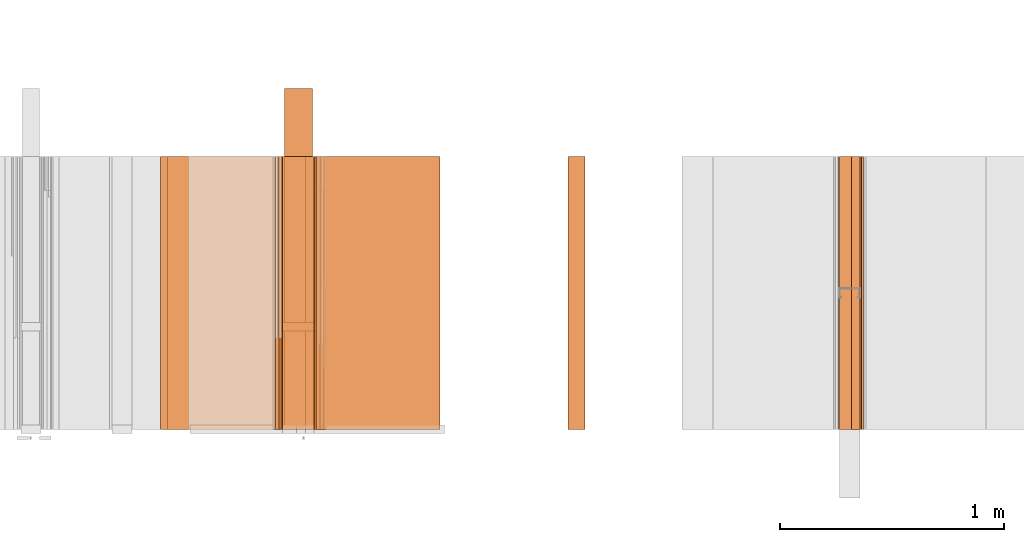
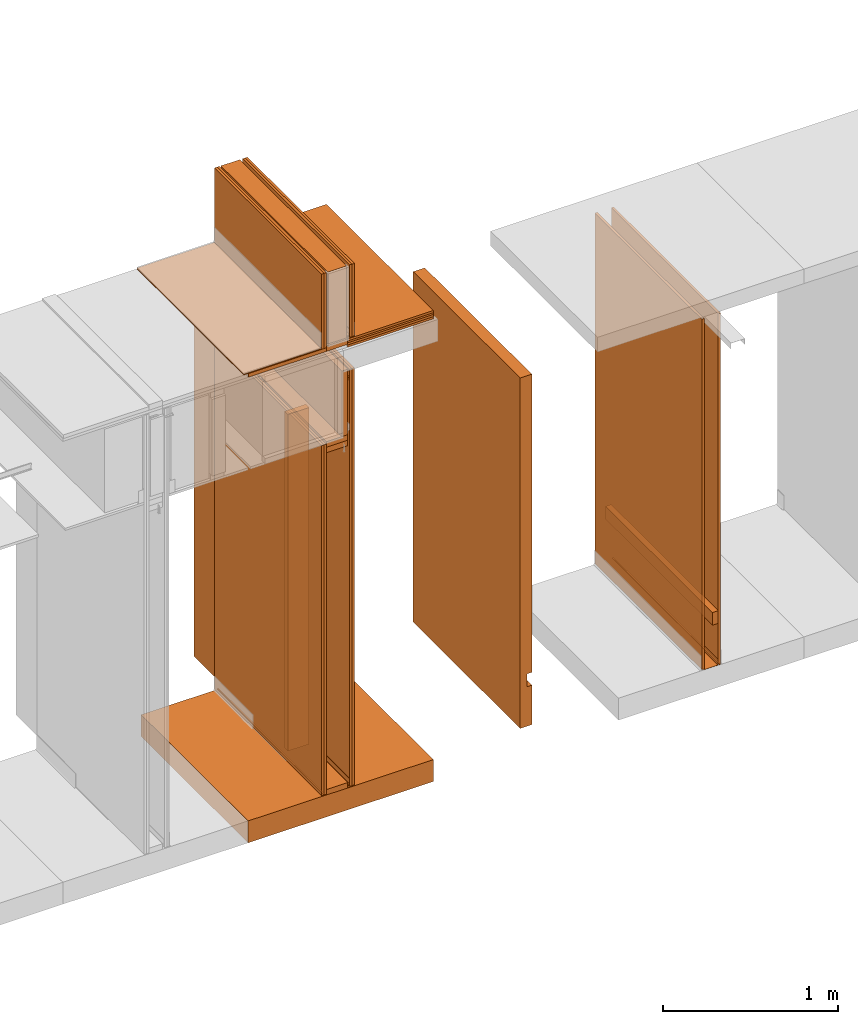
# One storey, part 11 of 38: 34 proxies.
"""IFC4 building model written with IfcOpenShell, lengths in feet."""

from ifc_helpers import new_model, entity, si_unit, converted_unit, frame, origin_with_axes, origin_2d_with_axis, place, context, subcontext, project, spatial, polyline, outline, extrude, material, element, save


model = new_model("IFC4")

# Units and contexts
model_context_1 = context("Model", 3, precision=1e-05, world=origin_with_axes())
plan_context = context("Plan", 2, precision=1e-05, world=origin_2d_with_axis())
model_context_2 = context("Model", 3, precision=1e-05, world=origin_with_axes())
context_of_model_1 = context(None, 3, precision=1e-05, world=origin_with_axes())
context_of_model_2 = context(None, 3, precision=1e-05, world=origin_with_axes())
body_context = subcontext(model_context_2, "Body", "Model", "MODEL_VIEW")
ifc_project = project(units=[converted_unit("PLANEANGLEUNIT", "degree", entity("IfcReal", 0.0174532925199433), si_unit("PLANEANGLEUNIT", "RADIAN"), dimensions=[0, 0, 0, 0, 0, 0, 0]), converted_unit("AREAUNIT", "square foot", entity("IfcReal", 0.09290304), si_unit("AREAUNIT", "SQUARE_METRE"), dimensions=[2, 0, 0, 0, 0, 0, 0]), converted_unit("LENGTHUNIT", "foot", entity("IfcReal", 0.3048), si_unit("LENGTHUNIT", "METRE"), dimensions=[1, 0, 0, 0, 0, 0, 0]), converted_unit("VOLUMEUNIT", "cubic foot", entity("IfcReal", 0.0283168467116885), si_unit("VOLUMEUNIT", "CUBIC_METRE"), dimensions=[3, 0, 0, 0, 0, 0, 0])], contexts=[model_context_1, plan_context, context_of_model_1, context_of_model_2])

# Site, building, storey
site_placement = place(None, origin_with_axes())
site = spatial("IfcSite", under=ifc_project, at=site_placement)
building_placement = place(site_placement, origin_with_axes())
building = spatial("IfcBuilding", under=site, at=building_placement, Name="Building")
storey_placement = place(building_placement, origin_with_axes())
storey = spatial("IfcBuildingStorey", under=building, at=storey_placement, Name="Storey")

# Proxies
ifc_material_1 = material(Category="sand")
proxy_1_placement = place(storey_placement, frame((1395.33335768332, 5.99999987860051, 0.0208333330815585), z_axis=(1.62920684942944e-07, -0.999999999999987, -1.23001694617954e-14), x_axis=(7.54979012640431e-08, 0.0, 0.999999999999997)))
element("IfcBuildingElementProxy", 1, at=proxy_1_placement, inside=storey, material=ifc_material_1, Name="Generic Models 138:Generic Models 1", PredefinedType="COMPLEX", context=body_context, shape_type="SweptSolid", body=[
    extrude(outline(polyline([(-0.0260419699942737, -4.00000004943587), (0.0260413650012626, -4.00000004943587), (0.0260419699942737, 4.00000004943587), (-0.0260413650012626, 4.00000004943587), (-0.0260419699942737, -4.00000004943587)])), frame((4.00000004943587, -0.0260413650012626, -3.91106639637913e-07), z_axis=(-1.16558848618949e-14, 0.0, -1.0), x_axis=(0.0, 1.0, 0.0)), (0.0, -1.16558848618949e-14, -1.0), 4.00000000752362),
])
proxy_2_placement = place(storey_placement, frame((1387.33330674059, 5.99999987860051, 10.1588545196013), z_axis=(4.37113882867379e-08, -0.999999999999999, -8.51092183247426e-15), x_axis=(1.94707183709394e-07, 0.0, 0.999999999999981)))
element("IfcBuildingElementProxy", 2, at=proxy_2_placement, inside=storey, Name="Generic Models 491:Generic Models 1", PredefinedType="COMPLEX", context=body_context, shape_type="SweptSolid", body=[
    extrude(outline(polyline([(-0.0208335148850138, -0.92447918700421), (0.0208331543336234, -0.92447918700421), (0.0208335148850138, 0.92447918700421), (-0.0208331543336234, 0.92447918700421), (-0.0208335148850138, -0.92447918700421)])), frame((0.0208335148850138, -0.92447918700421, -5.0131307678986e-07), z_axis=(0.0, 1.19209289550781e-07, -1.0), x_axis=(-1.0, 0.0, 0.0)), (0.0, -3.01153102455487e-09, -1.0), 4.00000000752362),
])
proxy_3_placement = place(storey_placement, frame((1387.33330674059, 5.99999987860051, 10.1093748423058), z_axis=(4.37113882867379e-08, -0.999999999999999, -8.51092183247426e-15), x_axis=(1.94707183709394e-07, 0.0, 0.999999999999981)))
element("IfcBuildingElementProxy", 3, at=proxy_3_placement, inside=storey, Name="Generic Models 492:Generic Models 1", PredefinedType="COMPLEX", context=body_context, shape_type="SweptSolid", body=[
    extrude(outline(polyline([(-0.0247397637874709, -0.92447918700421), (0.0247394032360805, -0.92447918700421), (0.0247397637874709, 0.92447918700421), (-0.0247394032360805, 0.92447918700421), (-0.0247397637874709, -0.92447918700421)])), frame((0.0247397637874709, -0.92447918700421, -5.0131307678986e-07), z_axis=(0.0, 1.19209289550781e-07, -1.0), x_axis=(-1.0, 0.0, 0.0)), (0.0, -3.01153102455487e-09, -1.0), 4.00000000752362),
])
proxy_4_placement = place(storey_placement, frame((1387.2083528774, 5.99999987860051, 8.06249971464863), z_axis=(4.37113882867379e-08, -0.999999999999999, -8.51092183247426e-15), x_axis=(1.94707183709394e-07, 0.0, 0.999999999999981)))
element("IfcBuildingElementProxy", 4, at=proxy_4_placement, inside=storey, Name="Generic Models 493:Generic Models 1", PredefinedType="COMPLEX", context=body_context, shape_type="SweptSolid", body=[
    extrude(outline(polyline([(-0.748697844311947, -0.0625000007724355), (0.748697893200271, -0.0625000007724355), (0.748697893200271, 0.0625000007724355), (-0.748697893200271, 0.0625000007724355), (-0.748697844311947, -0.0625000007724355)])), frame((0.748697893200271, -0.0624998541074631, -3.98557174431872e-07), z_axis=(-2.35432113122316e-14, 1.19209303761636e-07, -1.0), x_axis=(-1.0, -1.95893392174185e-07, 0.0)), (3.06085023993319e-09, 4.40009660651608e-11, -1.0), 4.00000000752362),
])
ifc_material_2 = material(Category="InsulationBatt")
proxy_5_placement = place(storey_placement, frame((1386.90327721944, 5.99999987860051, 10.2830629336239), z_axis=(4.37113882867379e-08, -0.999999999999999, -8.51092183247426e-15), x_axis=(1.94707183709394e-07, 0.0, 0.999999999999981)))
element("IfcBuildingElementProxy", 5, at=proxy_5_placement, inside=storey, material=ifc_material_2, Name="Generic Models 496:Generic Models 1", PredefinedType="COMPLEX", context=body_context, shape_type="SweptSolid", body=[
    extrude(outline(polyline([(-0.820806020201035, -0.20460231752768), (0.820806020201035, -0.20460231752768), (0.820805922424386, 0.20460231752768), (-0.820806020201035, 0.20460231752768), (-0.820806020201035, -0.20460231752768)])), frame((0.820806020201035, -0.204602158640626, -4.15497091384278e-07), z_axis=(-2.31266422028378e-14, 1.19209289550781e-07, -1.0), x_axis=(1.0, 1.94707183709397e-07, 0.0)), (-9.9594013036608e-09, 3.24397553264077e-09, -1.0), 4.00000000752362),
])
proxy_6_placement = place(storey_placement, frame((1391.05729230746, 5.99999909638733, 0.0546877993529863), z_axis=(1.62920684942944e-07, -0.999999999999987, -1.23001694617954e-14), x_axis=(7.54979012640431e-08, 0.0, 0.999999999999997)))
element("IfcBuildingElementProxy", 6, at=proxy_6_placement, inside=storey, material=ifc_material_2, Name="Generic Models 157:Generic Models 1", PredefinedType="COMPLEX", context=body_context, shape_type="SweptSolid", body=[
    extrude(outline(polyline([(1.62270213440647, -0.0872395766454106), (2.52313129701639, -0.0872395766454106), (2.52313129701639, 0.162760426444331), (-5.47686899740865, 0.162760365333926), (-5.47686860630206, -0.0872396194226942), (1.33103546820913, -0.0872395766454106), (1.33103546820913, 0.0117187520545318), (1.62270213440647, 0.0117187635127328), (1.62270213440647, -0.0872395766454106)])), frame((2.52313129701639, -0.162760218668954, -3.91106593014374e-07), z_axis=(-6.06266415447755e-15, -2.11475937672914e-14, -1.0), x_axis=(-1.0, -8.14417049355143e-08, 0.0)), (3.31386740271e-09, 5.71793279391386e-10, -1.0), 4.00000000752362),
])
ifc_material_3 = material()
proxy_7_placement = place(storey_placement, frame((1395.03128572399, 6.00000026970711, 2.46003406487815e-14), z_axis=(1.62920684942944e-07, -0.999999999999987, -1.23001694617954e-14), x_axis=(7.54979012640431e-08, 0.0, 0.999999999999997)))
element("IfcBuildingElementProxy", 7, at=proxy_7_placement, inside=storey, material=ifc_material_3, Name="Generic Models 15:Generic Models 1", PredefinedType="COMPLEX", context=body_context, shape_type="SweptSolid", body=[
    extrude(outline(polyline([(-0.0664062573136933, -0.151041662931599), (0.0690104038970364, -0.151041662931599), (0.0690104283411985, 0.151041662931599), (-0.0664062328695312, 0.151041662931599), (-0.0664062328695312, 0.145833333098669), (0.0638020923972286, 0.145833333098669), (0.0638020679530666, -0.14583334532075), (-0.0664062573136933, -0.14583334532075), (-0.0664062573136933, -0.151041662931599)])), frame((0.0690104283411985, -0.151041662931599, -8.48839891821795e-16), z_axis=(-1.2300178779158e-14, 3.03913346414728e-21, -1.0), x_axis=(-1.0, 0.0, 1.23001677677296e-14)), (1.22990073325919e-14, 0.0, -1.0), 4.00000000752362),
])
proxy_8_placement = place(storey_placement, frame((1394.97912149104, 5.99999987860051, 0.0208333330815585), z_axis=(1.62920684942944e-07, -0.999999999999987, -1.23001694617954e-14), x_axis=(7.54979012640431e-08, 0.0, 0.999999999999997)))
element("IfcBuildingElementProxy", 8, at=proxy_8_placement, inside=storey, material=ifc_material_1, Name="Generic Models 16:Generic Models 1", PredefinedType="COMPLEX", context=body_context, shape_type="SweptSolid", body=[
    extrude(outline(polyline([(-0.0260419699942737, -4.00000004943587), (0.0260413650012626, -4.00000004943587), (0.0260419699942737, 4.00000004943587), (-0.0260413650012626, 4.00000004943587), (-0.0260419699942737, -4.00000004943587)])), frame((4.00000004943587, -0.0260413650012626, -3.91106639637913e-07), z_axis=(-1.16558848618949e-14, 0.0, -1.0), x_axis=(0.0, 1.0, 0.0)), (0.0, -1.16558848618949e-14, -1.0), 4.00000000752362),
])
ifc_material_4 = material(Name="ACOUSTICAL SEALANT OR FIRE SEALANT, IF RATED WALL", Category="sealant")
proxy_9_placement = place(storey_placement, frame((1395.34967777923, 5.99999987860051, 0.0), z_axis=(1.62920684942944e-07, -0.999999999999987, -1.23001694617954e-14), x_axis=(7.54979012640431e-08, 0.0, 0.999999999999997)))
element("IfcBuildingElementProxy", 9, at=proxy_9_placement, inside=storey, material=ifc_material_4, Name="Generic Models 17:Generic Models 1", PredefinedType="COMPLEX", context=body_context, shape_type="SweptSolid", body=[
    extrude(outline(polyline([(0.0200664020800997, 8.59128858751497e-10), (-0.0066432067293312, 0.0162221848221589), (-0.0159632080916579, 0.00969531855440828), (-0.0174579961015171, -0.00158422060519838), (0.00925161041627367, -0.0178064048544472), (0.0107464022455331, -0.00652686626775058), (0.0200664020800997, 8.59128858751497e-10)])), frame((0.0104166680685394, -0.0185779756634176, -1.2812678144933e-16), z_axis=(-1.23001677677296e-14, 6.41066287393143e-22, -1.0), x_axis=(-0.519109845161438, -0.854707539081573, 6.38513764431026e-15)), (1.60595958753618e-09, 3.2119169546263e-09, -1.0), 4.0),
])
ifc_material_5 = material(Category="wood1")
proxy_10_placement = place(storey_placement, frame((1395.20830369684, 5.99999987860051, 0.955116717521287), z_axis=(1.62920684942944e-07, -0.999999999999987, -1.23001694617954e-14), x_axis=(7.54979012640431e-08, 0.0, 0.999999999999997)))
element("IfcBuildingElementProxy", 10, at=proxy_10_placement, inside=storey, material=ifc_material_5, Name="Generic Models 197:Generic Models 1", PredefinedType="COMPLEX", context=body_context, shape_type="SweptSolid", body=[
    extrude(outline(polyline([(-0.0625000129945165, -0.145833333098669), (0.0624999885503545, -0.145833333098669), (0.0625000129945165, 0.145833320876588), (-0.0624999885503545, 0.145833333098669), (-0.0625000129945165, -0.145833333098669)])), frame((0.145833333098669, -0.0624999885503545, -3.91106593014374e-07), z_axis=(0.0, 0.0, -1.0), x_axis=(0.0, -1.0, 0.0)), (0.0, 0.0, -1.0), 4.00000000752362),
])
proxy_11_placement = place(storey_placement, frame((1395.20830369684, 5.99999987860051, 0.955116717521287), z_axis=(1.62920684942944e-07, -0.999999999999987, -1.23001694617954e-14), x_axis=(7.54979012640431e-08, 0.0, 0.999999999999997)))
element("IfcBuildingElementProxy", 11, at=proxy_11_placement, inside=storey, material=ifc_material_5, Name="Generic Models 197:Generic Models 1", PredefinedType="COMPLEX", context=body_context, shape_type="SweptSolid", body=[
    extrude(outline(polyline([(-0.0625000007724355, -0.145833333098669), (0.0625000007724355, -0.145833333098669), (0.062499994661395, 0.145833333098669), (-0.062500006883476, 0.145833320876588), (-0.0625000007724355, -0.145833333098669)])), frame((0.145833333098669, -0.0624999885503545, -3.91106593014374e-07), z_axis=(0.0, 0.0, -1.0), x_axis=(-9.77766489995702e-08, 1.0, 0.0)), (-5.09253250680075e-10, -1.52775991857368e-09, -1.0), 4.00000000752362),
])
ifc_material_6 = material(Name="STRUCTURAL FLOOR", Category="concrete")
proxy_12_placement = place(storey_placement, frame((1385.18225802524, 5.99999987860051, -0.500000006179484), z_axis=(4.37113882867379e-08, -0.999999999999999, -8.51092183247426e-15), x_axis=(1.94707183709394e-07, 0.0, 0.999999999999981)))
element("IfcBuildingElementProxy", 12, at=proxy_12_placement, inside=storey, material=ifc_material_6, Name="Generic Models 238:Generic Models 1", PredefinedType="COMPLEX", context=body_context, shape_type="SweptSolid", body=[
    extrude(outline(polyline([(-0.250000003089742, -2.00000002471794), (0.250000003089742, -2.00000002471794), (0.250000003089742, 2.00000002471794), (-0.250000003089742, 2.00000002471794), (-0.250000003089742, -2.00000002471794)])), frame((0.250000394196335, -2.00000002471794, -6.29525198374314e-07), z_axis=(0.0, 1.19209289550781e-07, -1.0), x_axis=(1.0, 1.94707183709397e-07, 0.0)), (4.23038687413779e-10, -9.26340160134487e-09, -1.0), 4.00000000752362),
])
proxy_13_placement = place(storey_placement, frame((1386.87504245227, 5.99999987860051, 0.0), z_axis=(4.37113882867379e-08, -0.999999999999999, -8.51092183247426e-15), x_axis=(1.94707183709394e-07, 0.0, 0.999999999999981)))
element("IfcBuildingElementProxy", 13, at=proxy_13_placement, inside=storey, Name="Generic Models 435:Generic Models 1", PredefinedType="COMPLEX", context=body_context, shape_type="SweptSolid", body=[
    extrude(outline(polyline([(-0.229166659313863, -0.0625000007724355), (0.229166659313863, -0.0625000007724355), (0.229166659313863, 0.0625000007724355), (-0.229166683758025, 0.062499994661395), (-0.229166659313863, -0.0625000007724355)])), frame((0.0625000435497191, -0.229166659313863, -4.18425376004021e-07), z_axis=(0.0, 1.1920923981279e-07, -1.0), x_axis=(-1.94707183709397e-07, 1.0, 1.1920923981279e-07)), (-6.05387917573807e-09, -4.60778332156409e-10, -1.0), 4.00000000752362),
])
proxy_14_placement = place(storey_placement, frame((1387.37495802832, 5.99999987860051, 0.0208333330815585), z_axis=(4.37113882867379e-08, -0.999999999999999, -8.51092183247426e-15), x_axis=(1.94707183709394e-07, 0.0, 0.999999999999981)))
element("IfcBuildingElementProxy", 14, at=proxy_14_placement, inside=storey, Name="Generic Models 444:Generic Models 1", PredefinedType="COMPLEX", context=body_context, shape_type="SweptSolid", body=[
    extrude(outline(polyline([(-4.75911487118779, -0.0260416674977682), (4.75911487118779, -0.0260416674977682), (4.75911487118779, 0.0260416705532884), (-4.75911487118779, 0.0260416674977682), (-4.75911487118779, -0.0260416674977682)])), frame((4.75911487118779, -0.02604074167513, -3.94211021364806e-07), z_axis=(-3.29951011987777e-14, 1.19209154547661e-07, -1.0), x_axis=(1.0, 1.94707197920252e-07, -9.79668311805546e-15)), (-1.26761301455502e-09, 1.58962953911157e-10, -1.0), 4.00000000752362),
])
ifc_material_7 = material(Name="ACOUSTICAL SEALANT", Category="sealant")
proxy_15_placement = place(storey_placement, frame((1386.82287821932, 5.99999987860051, 0.0), z_axis=(4.37113882867379e-08, -0.999999999999999, -8.51092183247426e-15), x_axis=(1.94707183709394e-07, 0.0, 0.999999999999981)))
element("IfcBuildingElementProxy", 15, at=proxy_15_placement, inside=storey, material=ifc_material_7, Name="Generic Models 450:Generic Models 1", PredefinedType="COMPLEX", context=body_context, shape_type="SweptSolid", body=[
    extrude(outline(polyline([(0.0175297320783725, 1.21719171997307e-09), (-0.00760452534631872, 0.0185696447874344), (-0.0101125697065096, 0.00747135049587707), (-0.0199842895564484, 0.00181347361657025), (0.0051499686321229, -0.0167561721257142), (0.0150216861904215, -0.0110982927637972), (0.0175297320783725, 1.21719171997307e-09)])), frame((0.0104166711240596, -0.0171509025657545, -3.9315117507417e-07), z_axis=(1.14723269946382e-12, 1.19208550586336e-07, -1.0), x_axis=(-0.594228446483612, -0.804296314716339, -9.58762740310704e-08)), (-1.04803887790439e-10, 1.77274347978873e-10, -1.0), 4.00000000752362),
])
proxy_16_placement = place(storey_placement, frame((1386.77081410966, 5.99999987860051, 10.2083334146835), z_axis=(4.37113882867379e-08, -0.999999999999999, -8.51092183247426e-15), x_axis=(1.94707183709394e-07, 0.0, 0.999999999999981)))
element("IfcBuildingElementProxy", 16, at=proxy_16_placement, inside=storey, material=ifc_material_1, Name="Generic Models 452:Generic Models 1", PredefinedType="COMPLEX", context=body_context, shape_type="SweptSolid", body=[
    extrude(outline(polyline([(-0.0260416674977682, -0.858170779671256), (0.0260416674977682, -0.858170779671256), (0.0260416674977682, 0.858170779671256), (-0.0260416644422479, 0.858170779671256), (-0.0260416674977682, -0.858170779671256)])), frame((0.858170779671256, -0.026041499444154, -3.94210974741267e-07), z_axis=(-2.33946146282289e-14, 1.19209154547661e-07, -1.0), x_axis=(-1.94707169498542e-07, 1.0, 1.19209147442234e-07)), (2.84252066329316e-10, -1.26763999297452e-09, -1.0), 4.00000000752362),
])
proxy_17_placement = place(storey_placement, frame((1386.87504245227, 5.99999987860051, 7.81249968711472), z_axis=(4.37113882867379e-08, -0.999999999999999, -8.51092183247426e-15), x_axis=(1.94707183709394e-07, 0.0, 0.999999999999981)))
element("IfcBuildingElementProxy", 17, at=proxy_17_placement, inside=storey, Name="Generic Models 455:Generic Models 1", PredefinedType="COMPLEX", context=body_context, shape_type="SweptSolid", body=[
    extrude(outline(polyline([(-0.229166659313863, -0.0625000007724355), (0.229166659313863, -0.0625000007724355), (0.229166659313863, 0.0625000007724355), (-0.229166683758025, 0.062499994661395), (-0.229166659313863, -0.0625000007724355)])), frame((0.0625000435497191, -0.229166659313863, -4.18425376004021e-07), z_axis=(0.0, 1.1920923981279e-07, -1.0), x_axis=(-1.94707183709397e-07, 1.0, 1.1920923981279e-07)), (-6.05387917573807e-09, -4.60778332156409e-10, -1.0), 4.00000000752362),
])
proxy_18_placement = place(storey_placement, frame((1386.90327721944, 6.99999998873613, 0.125000001544871), z_axis=(4.37113882867379e-08, -0.999999999999999, -8.51092183247426e-15), x_axis=(1.94707183709394e-07, 0.0, 0.999999999999981)))
element("IfcBuildingElementProxy", 18, at=proxy_18_placement, inside=storey, Name="Generic Models 456:Generic Models 1", PredefinedType="COMPLEX", context=body_context, shape_type="SweptSolid", body=[
    extrude(outline(polyline([(-0.20460231752768, -3.83239327453253), (0.20460231752768, -3.83239327453253), (0.20460231752768, 3.83239327453253), (-0.20460231752768, 3.83239327453253), (-0.20460231752768, -3.83239327453253)])), frame((3.83239327453253, -0.204601571980737, -4.15497138007817e-07), z_axis=(-2.9337992403294e-14, 1.19209289550781e-07, -1.0), x_axis=(-1.94707183709397e-07, 1.0, 1.19209289550781e-07)), (-1.17899273677224e-10, -9.95937821102189e-09, -1.0), 4.00000000752362),
])
proxy_19_placement = place(storey_placement, frame((1386.87504245227, 5.99999987860051, 7.93749970088168), z_axis=(4.37113882867379e-08, -0.999999999999999, -8.51092183247426e-15), x_axis=(1.94707183709394e-07, 0.0, 0.999999999999981)))
element("IfcBuildingElementProxy", 19, at=proxy_19_placement, inside=storey, Name="Generic Models 457:Generic Models 1", PredefinedType="COMPLEX", context=body_context, shape_type="SweptSolid", body=[
    extrude(outline(polyline([(-0.229166659313863, -0.0625000007724355), (0.229166659313863, -0.0625000007724355), (0.229166659313863, 0.0625000007724355), (-0.229166683758025, 0.062499994661395), (-0.229166659313863, -0.0625000007724355)])), frame((0.0625000435497191, -0.229166659313863, -4.18425376004021e-07), z_axis=(0.0, 1.1920923981279e-07, -1.0), x_axis=(-1.94707183709397e-07, 1.0, 1.1920923981279e-07)), (-6.05387917573807e-09, -4.60778332156409e-10, -1.0), 4.00000000752362),
])
proxy_20_placement = place(storey_placement, frame((1386.82287821932, 5.99999987860051, 10.2083334146835), z_axis=(4.37113882867379e-08, -0.999999999999999, -8.51092183247426e-15), x_axis=(1.94707183709394e-07, 0.0, 0.999999999999981)))
element("IfcBuildingElementProxy", 20, at=proxy_20_placement, inside=storey, Name="Generic Models 458:Generic Models 1", PredefinedType="COMPLEX", context=body_context, shape_type="SweptSolid", body=[
    extrude(outline(polyline([(-0.858170779671256, -0.0260416674977682), (0.858170779671256, -0.0260416674977682), (0.858170779671256, 0.0260416644422479), (-0.858170779671256, 0.0260416674977682), (-0.858170779671256, -0.0260416674977682)])), frame((0.858170779671256, -0.026041499444154, -3.94210974741267e-07), z_axis=(-2.33946146282289e-14, 1.19209154547661e-07, -1.0), x_axis=(1.0, 1.94707183709397e-07, 0.0)), (-1.26763999297452e-09, -2.84249151993876e-10, -1.0), 4.00000000752362),
])
proxy_21_placement = place(storey_placement, frame((1386.82287821932, 5.99999987860051, 0.0208333330815585), z_axis=(4.37113882867379e-08, -0.999999999999999, -8.51092183247426e-15), x_axis=(1.94707183709394e-07, 0.0, 0.999999999999981)))
element("IfcBuildingElementProxy", 21, at=proxy_21_placement, inside=storey, Name="Generic Models 459:Generic Models 1", PredefinedType="COMPLEX", context=body_context, shape_type="SweptSolid", body=[
    extrude(outline(polyline([(-3.9947916829367, -0.0260416674977682), (3.9947916829367, -0.0260416674977682), (3.9947916829367, 0.0260416674977682), (-3.9947916829367, 0.0260416644422479), (-3.9947916829367, -0.0260416674977682)])), frame((3.9947916829367, -0.0260408883401024, -3.94211021364806e-07), z_axis=(-2.90771875707026e-14, 1.19209140336807e-07, -1.0), x_axis=(-1.0, -1.95043384110249e-07, 5.83554074000078e-15)), (1.26980481685024e-09, 4.38377840972226e-11, -1.0), 4.00000000752362),
])
proxy_22_placement = place(storey_placement, frame((1386.77081410966, 5.99999987860051, 0.0208333330815585), z_axis=(4.37113882867379e-08, -0.999999999999999, -8.51092183247426e-15), x_axis=(1.94707183709394e-07, 0.0, 0.999999999999981)))
element("IfcBuildingElementProxy", 22, at=proxy_22_placement, inside=storey, material=ifc_material_1, Name="Generic Models 460:Generic Models 1", PredefinedType="COMPLEX", context=body_context, shape_type="SweptSolid", body=[
    extrude(outline(polyline([(-3.9947916829367, -0.0260416674977682), (3.9947916829367, -0.0260416674977682), (3.9947916829367, 0.0260416644422479), (-3.9947916829367, 0.0260416674977682), (-3.9947916829367, -0.0260416674977682)])), frame((3.9947916829367, -0.0260408883401024, -3.94211021364806e-07), z_axis=(-2.90771875707026e-14, 1.19209140336807e-07, -1.0), x_axis=(1.0, 1.94707183709397e-07, -5.83554074000078e-15)), (-1.26761612317949e-09, -3.79597214772431e-10, -1.0), 4.00000000752362),
])
proxy_23_placement = place(storey_placement, frame((1387.42712226127, 5.99999987860051, 0.0208333330815585), z_axis=(4.37113882867379e-08, -0.999999999999999, -8.51092183247426e-15), x_axis=(1.94707183709394e-07, 0.0, 0.999999999999981)))
element("IfcBuildingElementProxy", 23, at=proxy_23_placement, inside=storey, Name="Generic Models 461:Generic Models 1", PredefinedType="COMPLEX", context=body_context, shape_type="SweptSolid", body=[
    extrude(outline(polyline([(-4.75911487118779, -0.0260416705532884), (4.75911487118779, -0.0260416705532884), (4.75911487118779, 0.0260416644422479), (-4.75911487118779, 0.0260416674977682), (-4.75911487118779, -0.0260416705532884)])), frame((4.75911487118779, -0.0260407386196098, -3.94211067988345e-07), z_axis=(-3.29951011987777e-14, 1.19209154547661e-07, -1.0), x_axis=(-1.0, -1.94536738717943e-07, 9.79668311805546e-15)), (1.26650312459731e-09, 4.3826126755464e-11, -1.0), 4.00000000752362),
])
proxy_24_placement = place(storey_placement, frame((1387.37495802832, 5.99999987860051, 10.2708330304604), z_axis=(4.37113882867379e-08, -0.999999999999999, -8.51092183247426e-15), x_axis=(1.94707183709394e-07, 0.0, 0.999999999999981)))
element("IfcBuildingElementProxy", 24, at=proxy_24_placement, inside=storey, Name="Generic Models 462:Generic Models 1", PredefinedType="COMPLEX", context=body_context, shape_type="SweptSolid", body=[
    extrude(outline(polyline([(-0.0260416674977682, -0.826920776229518), (0.0260416674977682, -0.826920776229518), (0.0260416674977682, 0.826920776229518), (-0.0260416644422479, 0.826920776229518), (-0.0260416674977682, -0.826920776229518)])), frame((0.826920776229518, -0.0260415055551945, -3.94210974741267e-07), z_axis=(-2.34116179676121e-14, 1.19209154547661e-07, -1.0), x_axis=(-1.94707169498542e-07, 1.0, 1.19209147442234e-07)), (2.77643186219478e-10, -1.26764032604143e-09, -1.0), 4.00000000752362),
])
proxy_25_placement = place(storey_placement, frame((1387.42712226127, 5.99999987860051, 10.2708330304604), z_axis=(4.37113882867379e-08, -0.999999999999999, -8.51092183247426e-15), x_axis=(1.94707183709394e-07, 0.0, 0.999999999999981)))
element("IfcBuildingElementProxy", 25, at=proxy_25_placement, inside=storey, Name="Generic Models 463:Generic Models 1", PredefinedType="COMPLEX", context=body_context, shape_type="SweptSolid", body=[
    extrude(outline(polyline([(-0.0260416674977682, -0.825750194196626), (0.0260416674977682, -0.825750194196626), (0.0260416674977682, 0.825750194196626), (-0.0260416644422479, 0.825750194196626), (-0.0260416674977682, -0.825750194196626)])), frame((0.825750194196626, -0.0260415055551945, -3.94210974741267e-07), z_axis=(-2.34448064125514e-14, 1.19209161653089e-07, -1.0), x_axis=(-1.94707169498542e-07, 1.0, 1.19209147442234e-07)), (3.34622968223286e-10, -1.26764032604143e-09, -1.0), 4.00000000752362),
])
for number, where, z_axis, x_axis, name in (
    (26, (1387.33330674059, 5.99999987860051, 10.2719844482702), (4.37113882867379e-08, -0.999999999999999, -8.51092183247426e-15), (1.94707183709394e-07, 0.0, 0.999999999999981), "Generic Models 464:Generic Models 1"),
    (27, (1387.33330674059, 5.99999987860051, 0.0115680431010901), (4.37113882867379e-08, -0.999999999999999, -8.51092183247426e-15), (1.94707183709394e-07, 0.0, 0.999999999999981), "Generic Models 469:Generic Models 1"),
):
    element("IfcBuildingElementProxy", number, at=place(storey_placement, frame(where, z_axis=z_axis, x_axis=x_axis)), inside=storey, Name=name, PredefinedType="COMPLEX", context=body_context, shape_type="SweptSolid", body=[
        extrude(outline(polyline([(0.0909011349023327, -1.52771368754651e-09), (0.106510742912142, -0.0224037100793183), (0.110784095768228, -0.0194262812803854), (0.0939412186719145, 0.00474751612851078), (-0.0261054912049157, 0.0262034236847025), (-0.0684096397260043, -0.00327164942784885), (-0.107302623764267, 0.00367967978369181), (-0.1082189865117, -0.00144740758497962), (-0.0672022875623284, -0.00877830727280086), (-0.0248981451522803, 0.0206967635481103), (0.0909011349023327, -1.52771368754651e-09)])), frame((0.106276176732982, -0.0204650267807087, -3.93546216320895e-07), z_axis=(-2.86421862789876e-12, 1.19209985882662e-07, -1.0), x_axis=(0.984400570392609, -0.175941362977028, -2.09736619183332e-08)), (-1.20826360028303e-09, -9.42844552431765e-11, -1.0), 4.00000000752362),
    ])
proxy_26_placement = place(storey_placement, frame((1386.87504245227, 3.44270835398376, 0.125000001544871), z_axis=(0.0, 0.0, 1.0), x_axis=(1.0, 0.0, 0.0)))
element("IfcBuildingElementProxy", 28, at=proxy_26_placement, inside=storey, Name="Generic Models 471:Generic Models 1", PredefinedType="COMPLEX", context=body_context, shape_type="SweptSolid", body=[
    extrude(outline(polyline([(-0.229166659313863, -0.0625000007724355), (0.229166659313863, -0.0625000007724355), (0.229166659313863, 0.0625000007724355), (-0.229166659313863, 0.0625000007724355), (-0.229166659313863, -0.0625000007724355)])), frame((0.229166659313863, 0.0625000007724355, 0.0), z_axis=(0.0, 0.0, -1.0), x_axis=(-1.0, 0.0, 0.0)), (0.0, 0.0, -1.0), 7.6848958487616),
])
proxy_27_placement = place(storey_placement, frame((1387.33330674059, 5.99999987860051, 10.0598959472236), z_axis=(4.37113882867379e-08, -0.999999999999999, -8.51092183247426e-15), x_axis=(1.94707183709394e-07, 0.0, 0.999999999999981)))
element("IfcBuildingElementProxy", 29, at=proxy_27_placement, inside=storey, Name="Generic Models 474:Generic Models 1", PredefinedType="COMPLEX", context=body_context, shape_type="SweptSolid", body=[
    extrude(outline(polyline([(-0.0247397637874709, -0.92447918700421), (0.0247394032360805, -0.92447918700421), (0.0247397637874709, 0.92447918700421), (-0.0247394032360805, 0.92447918700421), (-0.0247397637874709, -0.92447918700421)])), frame((0.0247397637874709, -0.92447918700421, -5.0131307678986e-07), z_axis=(0.0, 1.19209289550781e-07, -1.0), x_axis=(-1.0, 0.0, 0.0)), (0.0, -3.01153102455487e-09, -1.0), 4.00000000752362),
])
proxy_28_placement = place(storey_placement, frame((1386.87504245227, 5.99999987860051, 10.1250003329099), z_axis=(4.37113882867379e-08, -0.999999999999999, -8.51092183247426e-15), x_axis=(1.94707183709394e-07, 0.0, 0.999999999999981)))
element("IfcBuildingElementProxy", 30, at=proxy_28_placement, inside=storey, Name="Generic Models 475:Generic Models 1", PredefinedType="COMPLEX", context=body_context, shape_type="SweptSolid", body=[
    extrude(outline(polyline([(-0.229166659313863, -0.0625000007724355), (0.229166659313863, -0.0625000007724355), (0.229166659313863, 0.0625000007724355), (-0.229166683758025, 0.062499994661395), (-0.229166659313863, -0.0625000007724355)])), frame((0.0625000435497191, -0.229166659313863, -4.18425376004021e-07), z_axis=(0.0, 1.1920923981279e-07, -1.0), x_axis=(-1.94707183709397e-07, 1.0, 1.1920923981279e-07)), (-6.05387917573807e-09, -4.60778332156409e-10, -1.0), 4.00000000752362),
])
proxy_29_placement = place(storey_placement, frame((1387.33330674059, 5.99999987860051, 10.2005206693814), z_axis=(4.37113882867379e-08, -0.999999999999999, -8.51092183247426e-15), x_axis=(1.94707183709394e-07, 0.0, 0.999999999999981)))
element("IfcBuildingElementProxy", 31, at=proxy_29_placement, inside=storey, Name="Generic Models 476:Generic Models 1", PredefinedType="COMPLEX", context=body_context, shape_type="SweptSolid", body=[
    extrude(outline(polyline([(-0.0247397637874709, -0.92447918700421), (0.0247394032360805, -0.92447918700421), (0.0247397637874709, 0.92447918700421), (-0.0247394032360805, 0.92447918700421), (-0.0247397637874709, -0.92447918700421)])), frame((0.0247397637874709, -0.92447918700421, -5.0131307678986e-07), z_axis=(0.0, 1.19209289550781e-07, -1.0), x_axis=(-1.0, 0.0, 0.0)), (0.0, -3.01153102455487e-09, -1.0), 4.00000000752362),
])
proxy_30_placement = place(storey_placement, frame((1385.19267084717, 5.99999987860051, 10.1250003329099), z_axis=(4.37113882867379e-08, -0.999999999999999, -8.51092183247426e-15), x_axis=(1.94707183709394e-07, 0.0, 0.999999999999981)))
element("IfcBuildingElementProxy", 32, at=proxy_30_placement, inside=storey, Name="Generic Models 477:Generic Models 1", PredefinedType="COMPLEX", context=body_context, shape_type="SweptSolid", body=[
    extrude(outline(polyline([(-0.841145811900692, -0.0416666692186372), (0.841145811900692, -0.0416666692186372), (0.841145811900692, 0.0416666692186372), (-0.841145811900692, 0.0416666722741574), (-0.841145811900692, -0.0416666692186372)])), frame((0.0416668342167311, -0.841145811900692, -4.91378999315555e-07), z_axis=(0.0, 1.19209303761636e-07, -1.0), x_axis=(-1.94707183709397e-07, 1.0, 1.19209303761636e-07)), (-5.0397268580582e-09, 3.0524130445464e-10, -1.0), 4.00000000752362),
])
proxy_31_placement = place(storey_placement, frame((1387.33330674059, 5.99999987860051, 9.30323453712964), z_axis=(4.37113882867379e-08, -0.999999999999999, -8.51092183247426e-15), x_axis=(1.94707183709394e-07, 0.0, 0.999999999999981)))
element("IfcBuildingElementProxy", 33, at=proxy_31_placement, inside=storey, Name="Generic Models 479:Generic Models 1", PredefinedType="COMPLEX", context=body_context, shape_type="SweptSolid", body=[
    extrude(outline(polyline([(0.0909011349023327, -1.52771368754651e-09), (0.106510742912142, -0.0224037100793183), (0.110784095768228, -0.0194262812803854), (0.0939412186719145, 0.00474751612851078), (-0.0261054912049157, 0.0262034236847025), (-0.0684096397260043, -0.00327164942784885), (-0.107302623764267, 0.00367967978369181), (-0.1082189865117, -0.00144740758497962), (-0.0672022875623284, -0.00877830727280086), (-0.0248981451522803, 0.0206967635481103), (0.0909011349023327, -1.52771368754651e-09)])), frame((0.106276176732982, -0.0204650267807087, -3.93546216320895e-07), z_axis=(-2.86421862789876e-12, 1.19209985882662e-07, -1.0), x_axis=(0.984400570392609, -0.175941362977028, -2.09736619183332e-08)), (-1.20826360028303e-09, -9.42844552431765e-11, -1.0), 4.00000000752362),
])
proxy_32_placement = place(storey_placement, frame((1385.08854262785, 5.99999987860051, 10.2083334146835), z_axis=(4.37113882867379e-08, -0.999999999999999, -8.51092183247426e-15), x_axis=(1.94707183709394e-07, 0.0, 0.999999999999981)))
element("IfcBuildingElementProxy", 34, at=proxy_32_placement, inside=storey, Name="Generic Models 480:Generic Models 1", PredefinedType="COMPLEX", context=body_context, shape_type="SweptSolid", body=[
    extrude(outline(polyline([(0.841210344488539, 1.52776231444079e-09), (0.840952409690446, 0.0208317411555041), (-0.841210442265188, -1.5277603110856e-09), (-0.840952409690446, -0.0208317411555041), (0.841210344488539, 1.52776231444079e-09)])), frame((0.0104168307749931, -0.841145811900692, -4.91378999315555e-07), z_axis=(0.0, 1.19209303761636e-07, -1.0), x_axis=(-0.0123831462115049, 0.999923288822174, 1.19200159076627e-07)), (-9.4569436726033e-09, -5.15735579242893e-11, -1.0), 4.00000000752362),
])

save(model, "model.ifc")
